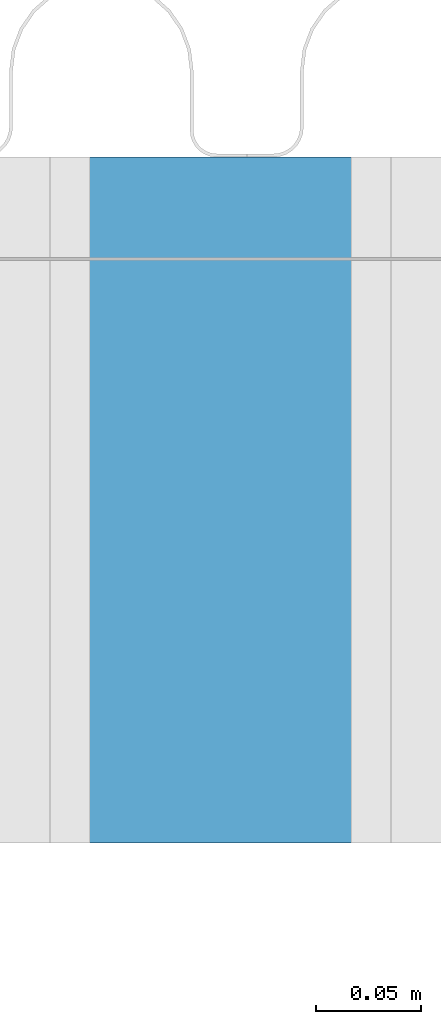
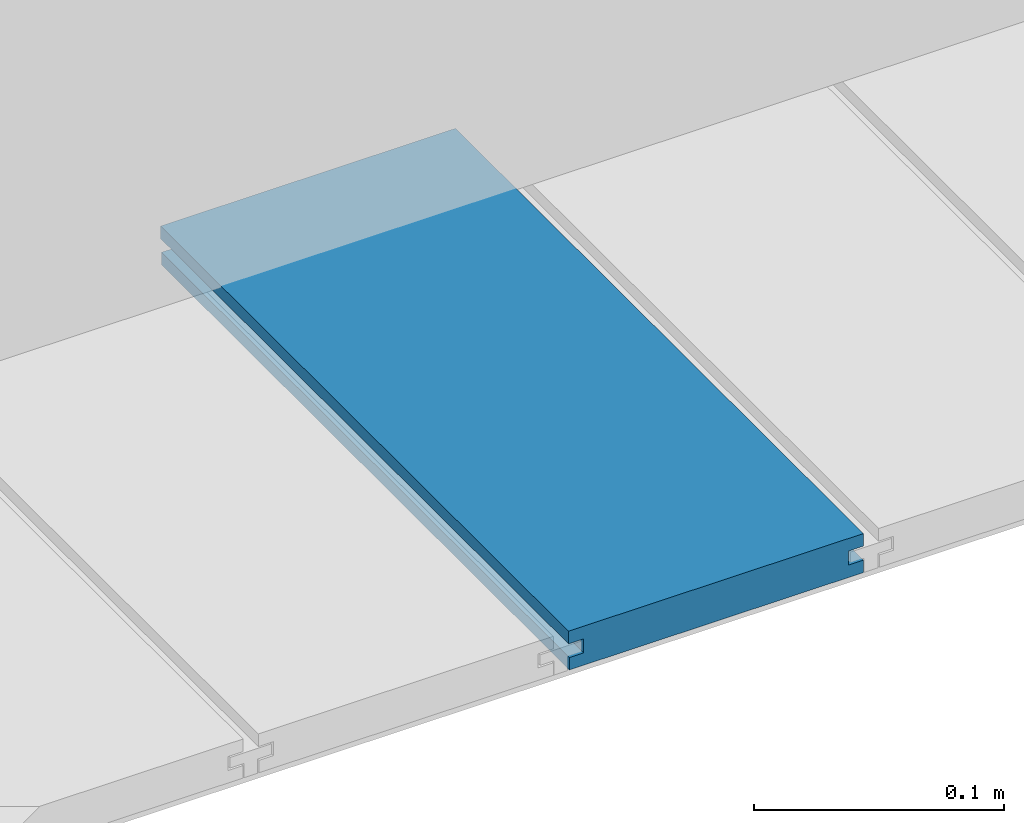
# One storey, part 22 of 33: 1 wall.
"""IFC4 building model written with IfcOpenShell, lengths in feet."""

from ifc_helpers import new_model, entity, si_unit, converted_unit, derived_unit, direction, frame, origin, place, context, subcontext, project, spatial, material, type_object, element, save


model = new_model("IFC4")

# Units and contexts
model_context = context("Model", 3, precision=0.0001, world=origin(), true_north=direction((6.12303176911189e-17, 1.0)))
body_context = subcontext(model_context, "Body", "Model", "MODEL_VIEW")
ifc_project = project(units=[converted_unit("LENGTHUNIT", "FOOT", entity("IfcRatioMeasure", 0.3048), si_unit("LENGTHUNIT", "METRE"), dimensions=[1, 0, 0, 0, 0, 0, 0]), converted_unit("AREAUNIT", "SQUARE FOOT", entity("IfcRatioMeasure", 0.09290304), si_unit("AREAUNIT", "SQUARE_METRE"), dimensions=[2, 0, 0, 0, 0, 0, 0]), converted_unit("VOLUMEUNIT", "CUBIC FOOT", entity("IfcRatioMeasure", 0.028316846592), si_unit("VOLUMEUNIT", "CUBIC_METRE"), dimensions=[3, 0, 0, 0, 0, 0, 0]), converted_unit("PLANEANGLEUNIT", "DEGREE", entity("IfcRatioMeasure", 0.0174532925199433), si_unit("PLANEANGLEUNIT", "RADIAN"), dimensions=[0, 0, 0, 0, 0, 0, 0]), si_unit("MASSUNIT", "GRAM", prefix="KILO"), derived_unit("MASSDENSITYUNIT", [(si_unit("MASSUNIT", "GRAM", prefix="KILO"), 1), (si_unit("LENGTHUNIT", "METRE"), -3)]), derived_unit("MOMENTOFINERTIAUNIT", [(si_unit("LENGTHUNIT", "METRE"), 4)]), si_unit("TIMEUNIT", "SECOND"), si_unit("FREQUENCYUNIT", "HERTZ"), si_unit("THERMODYNAMICTEMPERATUREUNIT", "DEGREE_CELSIUS"), derived_unit("THERMALTRANSMITTANCEUNIT", [(si_unit("MASSUNIT", "GRAM", prefix="KILO"), 1), (si_unit("THERMODYNAMICTEMPERATUREUNIT", "KELVIN"), -1), (si_unit("TIMEUNIT", "SECOND"), -3)]), derived_unit("VOLUMETRICFLOWRATEUNIT", [(si_unit("LENGTHUNIT", "METRE"), 3), (si_unit("TIMEUNIT", "SECOND"), -1)]), si_unit("ELECTRICCURRENTUNIT", "AMPERE"), si_unit("ELECTRICVOLTAGEUNIT", "VOLT"), si_unit("POWERUNIT", "WATT"), si_unit("FORCEUNIT", "NEWTON"), si_unit("ILLUMINANCEUNIT", "LUX"), si_unit("LUMINOUSFLUXUNIT", "LUMEN"), si_unit("LUMINOUSINTENSITYUNIT", "CANDELA"), derived_unit("USERDEFINED", [(si_unit("MASSUNIT", "GRAM", prefix="KILO"), -1), (si_unit("LENGTHUNIT", "METRE"), -2), (si_unit("TIMEUNIT", "SECOND"), 3), (si_unit("LUMINOUSFLUXUNIT", "LUMEN"), 1)]), derived_unit("LINEARVELOCITYUNIT", [(si_unit("LENGTHUNIT", "METRE"), 1), (si_unit("TIMEUNIT", "SECOND"), -1)]), si_unit("PRESSUREUNIT", "PASCAL"), derived_unit("USERDEFINED", [(si_unit("LENGTHUNIT", "METRE"), -2), (si_unit("MASSUNIT", "GRAM", prefix="KILO"), 1), (si_unit("TIMEUNIT", "SECOND"), -2)]), derived_unit("LINEARFORCEUNIT", [(si_unit("MASSUNIT", "GRAM", prefix="KILO"), 1), (si_unit("LENGTHUNIT", "METRE"), 1), (si_unit("TIMEUNIT", "SECOND"), -2), (si_unit("LENGTHUNIT", "METRE"), -1)]), derived_unit("PLANARFORCEUNIT", [(si_unit("MASSUNIT", "GRAM", prefix="KILO"), 1), (si_unit("LENGTHUNIT", "METRE"), 1), (si_unit("TIMEUNIT", "SECOND"), -2), (si_unit("LENGTHUNIT", "METRE"), -2)])], contexts=[model_context])

# Site, building, storey
site_placement = place(None, origin())
site = spatial("IfcSite", under=ifc_project, at=site_placement, CompositionType="ELEMENT")
building_placement = place(site_placement, origin())
building = spatial("IfcBuilding", under=site, at=building_placement, CompositionType="ELEMENT")
storey_placement = place(building_placement, frame((0.0, 0.0, 10.0)))
storey = spatial("IfcBuildingStorey", under=building, at=storey_placement, Name="2ND FLOOR", CompositionType="ELEMENT", Elevation=10.0000000000002)

# Wall
ifc_material = material(Name="COMPOSITE DECKING W/ HIDDEN FASTENERS", Category="Materials")
wall_type = type_object("IfcWallType", Name="Generic Models 715:Generic Models 1", PredefinedType="NOTDEFINED", material=ifc_material)
wall_placement = place(storey_placement, frame((1490.59189024029, 3.04611392999271, 0.682902157150139), z_axis=(0.0, 0.0, 1.0), x_axis=(0.0, 1.0, 0.0)))
cartesian_point_1 = entity("IfcCartesianPoint", [1.07004500651838, -0.446740923891412, 0.0])
vertex_point_1 = entity("IfcVertexPoint", cartesian_point_1)
cartesian_point_2 = entity("IfcCartesianPoint", [1.07004500651839, -0.00132475379450625, 0.0])
vertex_point_2 = entity("IfcVertexPoint", cartesian_point_2)
ifc_direction_1 = entity("IfcDirection", [0.0, 1.0, 0.0])
edge_curve_1 = entity("IfcEdgeCurve", vertex_point_1, vertex_point_2, entity("IfcTrimmedCurve", entity("IfcLine", cartesian_point_1, entity("IfcVector", ifc_direction_1, 1.0)), [cartesian_point_1], [cartesian_point_2], True, "CARTESIAN"), True)
cartesian_point_3 = entity("IfcCartesianPoint", [1.07004500651839, -0.00132475379450625, 0.0198779960861462])
vertex_point_3 = entity("IfcVertexPoint", cartesian_point_3)
ifc_direction_2 = entity("IfcDirection", [0.0, 0.0, 1.0])
edge_curve_2 = entity("IfcEdgeCurve", vertex_point_2, vertex_point_3, entity("IfcTrimmedCurve", entity("IfcLine", cartesian_point_2, entity("IfcVector", ifc_direction_2, 1.0)), [cartesian_point_2], [cartesian_point_3], True, "CARTESIAN"), True)
cartesian_point_4 = entity("IfcCartesianPoint", [1.07004500651839, -0.0228400010807945, 0.0198779960861462])
vertex_point_4 = entity("IfcVertexPoint", cartesian_point_4)
ifc_direction_3 = entity("IfcDirection", [0.0, -1.0, 0.0])
edge_curve_3 = entity("IfcEdgeCurve", vertex_point_3, vertex_point_4, entity("IfcTrimmedCurve", entity("IfcLine", cartesian_point_3, entity("IfcVector", ifc_direction_3, 1.0)), [cartesian_point_3], [cartesian_point_4], True, "CARTESIAN"), True)
cartesian_point_5 = entity("IfcCartesianPoint", [1.07004500651839, -0.0228400010807945, 0.0422987663426522])
vertex_point_5 = entity("IfcVertexPoint", cartesian_point_5)
edge_curve_4 = entity("IfcEdgeCurve", vertex_point_4, vertex_point_5, entity("IfcTrimmedCurve", entity("IfcLine", cartesian_point_4, entity("IfcVector", ifc_direction_2, 1.0)), [cartesian_point_4], [cartesian_point_5], True, "CARTESIAN"), True)
cartesian_point_6 = entity("IfcCartesianPoint", [1.07004500651839, 0.0, 0.0422987663426522])
vertex_point_6 = entity("IfcVertexPoint", cartesian_point_6)
edge_curve_5 = entity("IfcEdgeCurve", vertex_point_5, vertex_point_6, entity("IfcTrimmedCurve", entity("IfcLine", cartesian_point_5, entity("IfcVector", ifc_direction_1, 1.0)), [cartesian_point_5], [cartesian_point_6], True, "CARTESIAN"), True)
cartesian_point_7 = entity("IfcCartesianPoint", [1.07004500651839, 0.0, 0.0625000000000551])
vertex_point_7 = entity("IfcVertexPoint", cartesian_point_7)
edge_curve_6 = entity("IfcEdgeCurve", vertex_point_6, vertex_point_7, entity("IfcTrimmedCurve", entity("IfcLine", cartesian_point_6, entity("IfcVector", ifc_direction_2, 1.0)), [cartesian_point_6], [cartesian_point_7], True, "CARTESIAN"), True)
cartesian_point_8 = entity("IfcCartesianPoint", [1.07004500651838, -0.446740923891639, 0.0624999999999982])
vertex_point_8 = entity("IfcVertexPoint", cartesian_point_8)
edge_curve_7 = entity("IfcEdgeCurve", vertex_point_7, vertex_point_8, entity("IfcTrimmedCurve", entity("IfcLine", cartesian_point_7, entity("IfcVector", ifc_direction_3, 1.0)), [cartesian_point_7], [cartesian_point_8], True, "CARTESIAN"), True)
cartesian_point_9 = entity("IfcCartesianPoint", [1.07004500651838, -0.446740923891639, 0.0422987663426522])
vertex_point_9 = entity("IfcVertexPoint", cartesian_point_9)
ifc_direction_4 = entity("IfcDirection", [0.0, 0.0, -1.0])
edge_curve_8 = entity("IfcEdgeCurve", vertex_point_8, vertex_point_9, entity("IfcTrimmedCurve", entity("IfcLine", cartesian_point_8, entity("IfcVector", ifc_direction_4, 1.0)), [cartesian_point_8], [cartesian_point_9], True, "CARTESIAN"), True)
cartesian_point_10 = entity("IfcCartesianPoint", [1.07004500651838, -0.423900922810617, 0.0422987663426522])
vertex_point_10 = entity("IfcVertexPoint", cartesian_point_10)
edge_curve_9 = entity("IfcEdgeCurve", vertex_point_9, vertex_point_10, entity("IfcTrimmedCurve", entity("IfcLine", cartesian_point_9, entity("IfcVector", ifc_direction_1, 1.0)), [cartesian_point_9], [cartesian_point_10], True, "CARTESIAN"), True)
cartesian_point_11 = entity("IfcCartesianPoint", [1.07004500651838, -0.423900922810617, 0.0198779960861462])
vertex_point_11 = entity("IfcVertexPoint", cartesian_point_11)
edge_curve_10 = entity("IfcEdgeCurve", vertex_point_10, vertex_point_11, entity("IfcTrimmedCurve", entity("IfcLine", cartesian_point_10, entity("IfcVector", ifc_direction_4, 1.0)), [cartesian_point_10], [cartesian_point_11], True, "CARTESIAN"), True)
cartesian_point_12 = entity("IfcCartesianPoint", [1.07004500651838, -0.446740923891412, 0.0198779960861462])
vertex_point_12 = entity("IfcVertexPoint", cartesian_point_12)
edge_curve_11 = entity("IfcEdgeCurve", vertex_point_11, vertex_point_12, entity("IfcTrimmedCurve", entity("IfcLine", cartesian_point_11, entity("IfcVector", ifc_direction_3, 1.0)), [cartesian_point_11], [cartesian_point_12], True, "CARTESIAN"), True)
edge_curve_12 = entity("IfcEdgeCurve", vertex_point_12, vertex_point_1, entity("IfcTrimmedCurve", entity("IfcLine", cartesian_point_12, entity("IfcVector", ifc_direction_4, 1.0)), [cartesian_point_12], [cartesian_point_1], True, "CARTESIAN"), True)
ifc_direction_5 = entity("IfcDirection", [1.0, 0.0, 0.0])
cartesian_point_13 = entity("IfcCartesianPoint", [0.0, -0.446740923891412, 0.0])
vertex_point_13 = entity("IfcVertexPoint", cartesian_point_13)
cartesian_point_14 = entity("IfcCartesianPoint", [0.0, -0.446740923891412, 0.0198779960861462])
vertex_point_14 = entity("IfcVertexPoint", cartesian_point_14)
edge_curve_13 = entity("IfcEdgeCurve", vertex_point_13, vertex_point_14, entity("IfcTrimmedCurve", entity("IfcLine", cartesian_point_13, entity("IfcVector", ifc_direction_2, 1.0)), [cartesian_point_13], [cartesian_point_14], True, "CARTESIAN"), True)
cartesian_point_15 = entity("IfcCartesianPoint", [0.0, -0.423900922810617, 0.0198779960861462])
vertex_point_15 = entity("IfcVertexPoint", cartesian_point_15)
edge_curve_14 = entity("IfcEdgeCurve", vertex_point_14, vertex_point_15, entity("IfcTrimmedCurve", entity("IfcLine", cartesian_point_14, entity("IfcVector", ifc_direction_1, 1.0)), [cartesian_point_14], [cartesian_point_15], True, "CARTESIAN"), True)
cartesian_point_16 = entity("IfcCartesianPoint", [0.0, -0.423900922810617, 0.0422987663426522])
vertex_point_16 = entity("IfcVertexPoint", cartesian_point_16)
edge_curve_15 = entity("IfcEdgeCurve", vertex_point_15, vertex_point_16, entity("IfcTrimmedCurve", entity("IfcLine", cartesian_point_15, entity("IfcVector", ifc_direction_2, 1.0)), [cartesian_point_15], [cartesian_point_16], True, "CARTESIAN"), True)
cartesian_point_17 = entity("IfcCartesianPoint", [0.0, -0.446740923891639, 0.0422987663426522])
vertex_point_17 = entity("IfcVertexPoint", cartesian_point_17)
edge_curve_16 = entity("IfcEdgeCurve", vertex_point_16, vertex_point_17, entity("IfcTrimmedCurve", entity("IfcLine", cartesian_point_16, entity("IfcVector", ifc_direction_3, 1.0)), [cartesian_point_16], [cartesian_point_17], True, "CARTESIAN"), True)
cartesian_point_18 = entity("IfcCartesianPoint", [0.0, -0.446740923891639, 0.0624999999999982])
vertex_point_18 = entity("IfcVertexPoint", cartesian_point_18)
edge_curve_17 = entity("IfcEdgeCurve", vertex_point_17, vertex_point_18, entity("IfcTrimmedCurve", entity("IfcLine", cartesian_point_17, entity("IfcVector", ifc_direction_2, 1.0)), [cartesian_point_17], [cartesian_point_18], True, "CARTESIAN"), True)
cartesian_point_19 = entity("IfcCartesianPoint", [0.0, 0.0, 0.0625000000000551])
vertex_point_19 = entity("IfcVertexPoint", cartesian_point_19)
edge_curve_18 = entity("IfcEdgeCurve", vertex_point_18, vertex_point_19, entity("IfcTrimmedCurve", entity("IfcLine", cartesian_point_18, entity("IfcVector", ifc_direction_1, 1.0)), [cartesian_point_18], [cartesian_point_19], True, "CARTESIAN"), True)
cartesian_point_20 = entity("IfcCartesianPoint", [0.0, 0.0, 0.0422987663426522])
vertex_point_20 = entity("IfcVertexPoint", cartesian_point_20)
edge_curve_19 = entity("IfcEdgeCurve", vertex_point_19, vertex_point_20, entity("IfcTrimmedCurve", entity("IfcLine", cartesian_point_19, entity("IfcVector", ifc_direction_4, 1.0)), [cartesian_point_19], [cartesian_point_20], True, "CARTESIAN"), True)
cartesian_point_21 = entity("IfcCartesianPoint", [0.0, -0.0228400010807945, 0.0422987663426522])
vertex_point_21 = entity("IfcVertexPoint", cartesian_point_21)
edge_curve_20 = entity("IfcEdgeCurve", vertex_point_20, vertex_point_21, entity("IfcTrimmedCurve", entity("IfcLine", cartesian_point_20, entity("IfcVector", ifc_direction_3, 1.0)), [cartesian_point_20], [cartesian_point_21], True, "CARTESIAN"), True)
cartesian_point_22 = entity("IfcCartesianPoint", [0.0, -0.0228400010807945, 0.0198779960861462])
vertex_point_22 = entity("IfcVertexPoint", cartesian_point_22)
edge_curve_21 = entity("IfcEdgeCurve", vertex_point_21, vertex_point_22, entity("IfcTrimmedCurve", entity("IfcLine", cartesian_point_21, entity("IfcVector", ifc_direction_4, 1.0)), [cartesian_point_21], [cartesian_point_22], True, "CARTESIAN"), True)
cartesian_point_23 = entity("IfcCartesianPoint", [0.0, -0.00132475379450625, 0.0198779960861462])
vertex_point_23 = entity("IfcVertexPoint", cartesian_point_23)
edge_curve_22 = entity("IfcEdgeCurve", vertex_point_22, vertex_point_23, entity("IfcTrimmedCurve", entity("IfcLine", cartesian_point_22, entity("IfcVector", ifc_direction_1, 1.0)), [cartesian_point_22], [cartesian_point_23], True, "CARTESIAN"), True)
cartesian_point_24 = entity("IfcCartesianPoint", [0.0, -0.00132475379450625, 0.0])
vertex_point_24 = entity("IfcVertexPoint", cartesian_point_24)
edge_curve_23 = entity("IfcEdgeCurve", vertex_point_23, vertex_point_24, entity("IfcTrimmedCurve", entity("IfcLine", cartesian_point_23, entity("IfcVector", ifc_direction_4, 1.0)), [cartesian_point_23], [cartesian_point_24], True, "CARTESIAN"), True)
edge_curve_24 = entity("IfcEdgeCurve", vertex_point_24, vertex_point_13, entity("IfcTrimmedCurve", entity("IfcLine", cartesian_point_24, entity("IfcVector", ifc_direction_3, 1.0)), [cartesian_point_24], [cartesian_point_13], True, "CARTESIAN"), True)
ifc_direction_6 = entity("IfcDirection", [-1.0, 0.0, 0.0])
edge_curve_25 = entity("IfcEdgeCurve", vertex_point_13, vertex_point_1, entity("IfcTrimmedCurve", entity("IfcLine", cartesian_point_13, entity("IfcVector", ifc_direction_5, 1.0)), [cartesian_point_13], [cartesian_point_1], True, "CARTESIAN"), True)
edge_curve_26 = entity("IfcEdgeCurve", vertex_point_12, vertex_point_14, entity("IfcTrimmedCurve", entity("IfcLine", cartesian_point_14, entity("IfcVector", ifc_direction_6, 1.0)), [cartesian_point_12], [cartesian_point_14], True, "CARTESIAN"), True)
edge_curve_27 = entity("IfcEdgeCurve", vertex_point_18, vertex_point_8, entity("IfcTrimmedCurve", entity("IfcLine", cartesian_point_18, entity("IfcVector", ifc_direction_5, 1.0)), [cartesian_point_18], [cartesian_point_8], True, "CARTESIAN"), True)
edge_curve_28 = entity("IfcEdgeCurve", vertex_point_7, vertex_point_19, entity("IfcTrimmedCurve", entity("IfcLine", cartesian_point_19, entity("IfcVector", ifc_direction_6, 1.0)), [cartesian_point_7], [cartesian_point_19], True, "CARTESIAN"), True)
edge_curve_29 = entity("IfcEdgeCurve", vertex_point_6, vertex_point_20, entity("IfcTrimmedCurve", entity("IfcLine", cartesian_point_20, entity("IfcVector", ifc_direction_6, 1.0)), [cartesian_point_6], [cartesian_point_20], True, "CARTESIAN"), True)
edge_curve_30 = entity("IfcEdgeCurve", vertex_point_24, vertex_point_2, entity("IfcTrimmedCurve", entity("IfcLine", cartesian_point_24, entity("IfcVector", ifc_direction_5, 1.0)), [cartesian_point_24], [cartesian_point_2], True, "CARTESIAN"), True)
edge_curve_31 = entity("IfcEdgeCurve", vertex_point_17, vertex_point_9, entity("IfcTrimmedCurve", entity("IfcLine", cartesian_point_17, entity("IfcVector", ifc_direction_5, 1.0)), [cartesian_point_17], [cartesian_point_9], True, "CARTESIAN"), True)
edge_curve_32 = entity("IfcEdgeCurve", vertex_point_5, vertex_point_21, entity("IfcTrimmedCurve", entity("IfcLine", cartesian_point_21, entity("IfcVector", ifc_direction_6, 1.0)), [cartesian_point_5], [cartesian_point_21], True, "CARTESIAN"), True)
edge_curve_33 = entity("IfcEdgeCurve", vertex_point_4, vertex_point_22, entity("IfcTrimmedCurve", entity("IfcLine", cartesian_point_22, entity("IfcVector", ifc_direction_6, 1.0)), [cartesian_point_4], [cartesian_point_22], True, "CARTESIAN"), True)
edge_curve_34 = entity("IfcEdgeCurve", vertex_point_3, vertex_point_23, entity("IfcTrimmedCurve", entity("IfcLine", cartesian_point_23, entity("IfcVector", ifc_direction_6, 1.0)), [cartesian_point_3], [cartesian_point_23], True, "CARTESIAN"), True)
edge_curve_35 = entity("IfcEdgeCurve", vertex_point_11, vertex_point_15, entity("IfcTrimmedCurve", entity("IfcLine", cartesian_point_15, entity("IfcVector", ifc_direction_6, 1.0)), [cartesian_point_11], [cartesian_point_15], True, "CARTESIAN"), True)
edge_curve_36 = entity("IfcEdgeCurve", vertex_point_10, vertex_point_16, entity("IfcTrimmedCurve", entity("IfcLine", cartesian_point_16, entity("IfcVector", ifc_direction_6, 1.0)), [cartesian_point_10], [cartesian_point_16], True, "CARTESIAN"), True)
element("IfcWall", 1, at=wall_placement, inside=storey, type_object=wall_type, material=ifc_material, Name="Generic Models 715:Generic Models 1", ObjectType="Generic Models 715:Generic Models 1", PredefinedType="NOTDEFINED", context=body_context, shape_type="AdvancedBrep", body=[
    entity("IfcAdvancedBrep", entity("IfcClosedShell", [entity("IfcAdvancedFace", [entity("IfcFaceOuterBound", entity("IfcEdgeLoop", [entity("IfcOrientedEdge", None, None, edge_curve_1, True), entity("IfcOrientedEdge", None, None, edge_curve_2, True), entity("IfcOrientedEdge", None, None, edge_curve_3, True), entity("IfcOrientedEdge", None, None, edge_curve_4, True), entity("IfcOrientedEdge", None, None, edge_curve_5, True), entity("IfcOrientedEdge", None, None, edge_curve_6, True), entity("IfcOrientedEdge", None, None, edge_curve_7, True), entity("IfcOrientedEdge", None, None, edge_curve_8, True), entity("IfcOrientedEdge", None, None, edge_curve_9, True), entity("IfcOrientedEdge", None, None, edge_curve_10, True), entity("IfcOrientedEdge", None, None, edge_curve_11, True), entity("IfcOrientedEdge", None, None, edge_curve_12, True)]), True)], entity("IfcPlane", entity("IfcAxis2Placement3D", entity("IfcCartesianPoint", [1.07004500651838, -0.446740923891412, -0.0208333333328241]), ifc_direction_5, ifc_direction_4)), True), entity("IfcAdvancedFace", [entity("IfcFaceOuterBound", entity("IfcEdgeLoop", [entity("IfcOrientedEdge", None, None, edge_curve_13, True), entity("IfcOrientedEdge", None, None, edge_curve_14, True), entity("IfcOrientedEdge", None, None, edge_curve_15, True), entity("IfcOrientedEdge", None, None, edge_curve_16, True), entity("IfcOrientedEdge", None, None, edge_curve_17, True), entity("IfcOrientedEdge", None, None, edge_curve_18, True), entity("IfcOrientedEdge", None, None, edge_curve_19, True), entity("IfcOrientedEdge", None, None, edge_curve_20, True), entity("IfcOrientedEdge", None, None, edge_curve_21, True), entity("IfcOrientedEdge", None, None, edge_curve_22, True), entity("IfcOrientedEdge", None, None, edge_curve_23, True), entity("IfcOrientedEdge", None, None, edge_curve_24, True)]), True)], entity("IfcPlane", entity("IfcAxis2Placement3D", entity("IfcCartesianPoint", [0.0, -0.446740923891412, -0.0208333333328241]), ifc_direction_6, ifc_direction_2)), True), entity("IfcAdvancedFace", [entity("IfcFaceOuterBound", entity("IfcEdgeLoop", [entity("IfcOrientedEdge", None, None, edge_curve_13, False), entity("IfcOrientedEdge", None, None, edge_curve_25, True), entity("IfcOrientedEdge", None, None, edge_curve_12, False), entity("IfcOrientedEdge", None, None, edge_curve_26, True)]), True)], entity("IfcPlane", entity("IfcAxis2Placement3D", cartesian_point_13, ifc_direction_3, ifc_direction_5)), True), entity("IfcAdvancedFace", [entity("IfcFaceOuterBound", entity("IfcEdgeLoop", [entity("IfcOrientedEdge", None, None, edge_curve_18, False), entity("IfcOrientedEdge", None, None, edge_curve_27, True), entity("IfcOrientedEdge", None, None, edge_curve_7, False), entity("IfcOrientedEdge", None, None, edge_curve_28, True)]), True)], entity("IfcPlane", entity("IfcAxis2Placement3D", cartesian_point_18, ifc_direction_2, ifc_direction_5)), True), entity("IfcAdvancedFace", [entity("IfcFaceOuterBound", entity("IfcEdgeLoop", [entity("IfcOrientedEdge", None, None, edge_curve_19, False), entity("IfcOrientedEdge", None, None, edge_curve_28, False), entity("IfcOrientedEdge", None, None, edge_curve_6, False), entity("IfcOrientedEdge", None, None, edge_curve_29, True)]), True)], entity("IfcPlane", entity("IfcAxis2Placement3D", cartesian_point_19, ifc_direction_1, ifc_direction_5)), True), entity("IfcAdvancedFace", [entity("IfcFaceOuterBound", entity("IfcEdgeLoop", [entity("IfcOrientedEdge", None, None, edge_curve_24, False), entity("IfcOrientedEdge", None, None, edge_curve_30, True), entity("IfcOrientedEdge", None, None, edge_curve_1, False), entity("IfcOrientedEdge", None, None, edge_curve_25, False)]), True)], entity("IfcPlane", entity("IfcAxis2Placement3D", cartesian_point_24, ifc_direction_4, ifc_direction_5)), True), entity("IfcAdvancedFace", [entity("IfcFaceOuterBound", entity("IfcEdgeLoop", [entity("IfcOrientedEdge", None, None, edge_curve_17, False), entity("IfcOrientedEdge", None, None, edge_curve_31, True), entity("IfcOrientedEdge", None, None, edge_curve_8, False), entity("IfcOrientedEdge", None, None, edge_curve_27, False)]), True)], entity("IfcPlane", entity("IfcAxis2Placement3D", cartesian_point_17, ifc_direction_3, ifc_direction_5)), True), entity("IfcAdvancedFace", [entity("IfcFaceOuterBound", entity("IfcEdgeLoop", [entity("IfcOrientedEdge", None, None, edge_curve_20, False), entity("IfcOrientedEdge", None, None, edge_curve_29, False), entity("IfcOrientedEdge", None, None, edge_curve_5, False), entity("IfcOrientedEdge", None, None, edge_curve_32, True)]), True)], entity("IfcPlane", entity("IfcAxis2Placement3D", cartesian_point_20, ifc_direction_4, ifc_direction_5)), True), entity("IfcAdvancedFace", [entity("IfcFaceOuterBound", entity("IfcEdgeLoop", [entity("IfcOrientedEdge", None, None, edge_curve_21, False), entity("IfcOrientedEdge", None, None, edge_curve_32, False), entity("IfcOrientedEdge", None, None, edge_curve_4, False), entity("IfcOrientedEdge", None, None, edge_curve_33, True)]), True)], entity("IfcPlane", entity("IfcAxis2Placement3D", cartesian_point_21, ifc_direction_1, ifc_direction_5)), True), entity("IfcAdvancedFace", [entity("IfcFaceOuterBound", entity("IfcEdgeLoop", [entity("IfcOrientedEdge", None, None, edge_curve_22, False), entity("IfcOrientedEdge", None, None, edge_curve_33, False), entity("IfcOrientedEdge", None, None, edge_curve_3, False), entity("IfcOrientedEdge", None, None, edge_curve_34, True)]), True)], entity("IfcPlane", entity("IfcAxis2Placement3D", cartesian_point_22, ifc_direction_2, ifc_direction_5)), True), entity("IfcAdvancedFace", [entity("IfcFaceOuterBound", entity("IfcEdgeLoop", [entity("IfcOrientedEdge", None, None, edge_curve_23, False), entity("IfcOrientedEdge", None, None, edge_curve_34, False), entity("IfcOrientedEdge", None, None, edge_curve_2, False), entity("IfcOrientedEdge", None, None, edge_curve_30, False)]), True)], entity("IfcPlane", entity("IfcAxis2Placement3D", cartesian_point_23, ifc_direction_1, ifc_direction_5)), True), entity("IfcAdvancedFace", [entity("IfcFaceOuterBound", entity("IfcEdgeLoop", [entity("IfcOrientedEdge", None, None, edge_curve_14, False), entity("IfcOrientedEdge", None, None, edge_curve_26, False), entity("IfcOrientedEdge", None, None, edge_curve_11, False), entity("IfcOrientedEdge", None, None, edge_curve_35, True)]), True)], entity("IfcPlane", entity("IfcAxis2Placement3D", cartesian_point_14, ifc_direction_2, ifc_direction_5)), True), entity("IfcAdvancedFace", [entity("IfcFaceOuterBound", entity("IfcEdgeLoop", [entity("IfcOrientedEdge", None, None, edge_curve_15, False), entity("IfcOrientedEdge", None, None, edge_curve_35, False), entity("IfcOrientedEdge", None, None, edge_curve_10, False), entity("IfcOrientedEdge", None, None, edge_curve_36, True)]), True)], entity("IfcPlane", entity("IfcAxis2Placement3D", cartesian_point_15, ifc_direction_3, ifc_direction_5)), True), entity("IfcAdvancedFace", [entity("IfcFaceOuterBound", entity("IfcEdgeLoop", [entity("IfcOrientedEdge", None, None, edge_curve_16, False), entity("IfcOrientedEdge", None, None, edge_curve_36, False), entity("IfcOrientedEdge", None, None, edge_curve_9, False), entity("IfcOrientedEdge", None, None, edge_curve_31, False)]), True)], entity("IfcPlane", entity("IfcAxis2Placement3D", cartesian_point_16, ifc_direction_4, ifc_direction_5)), True)])),
])

save(model, "model.ifc")
